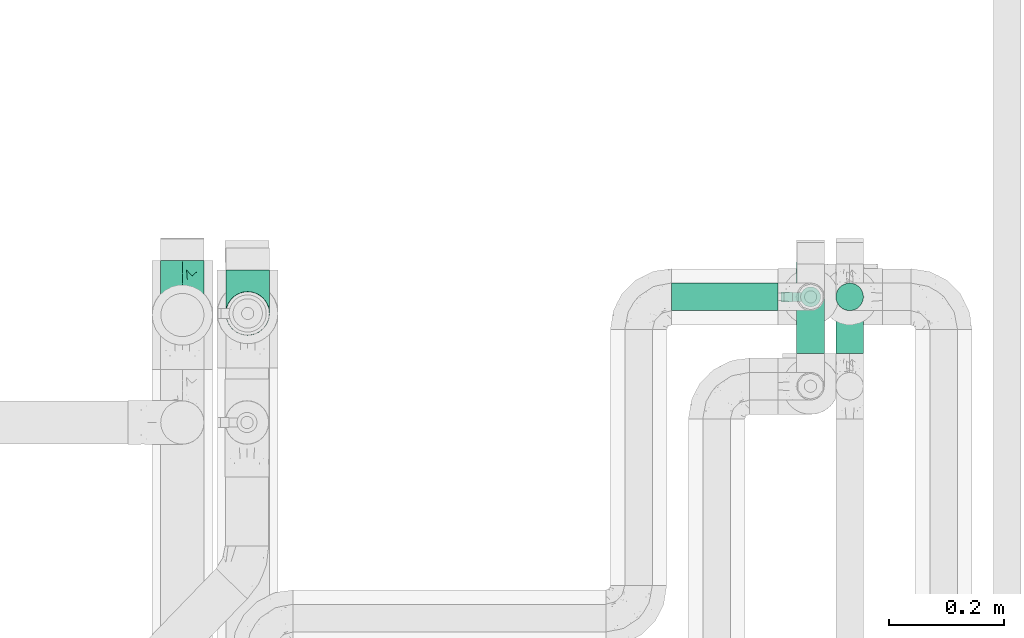
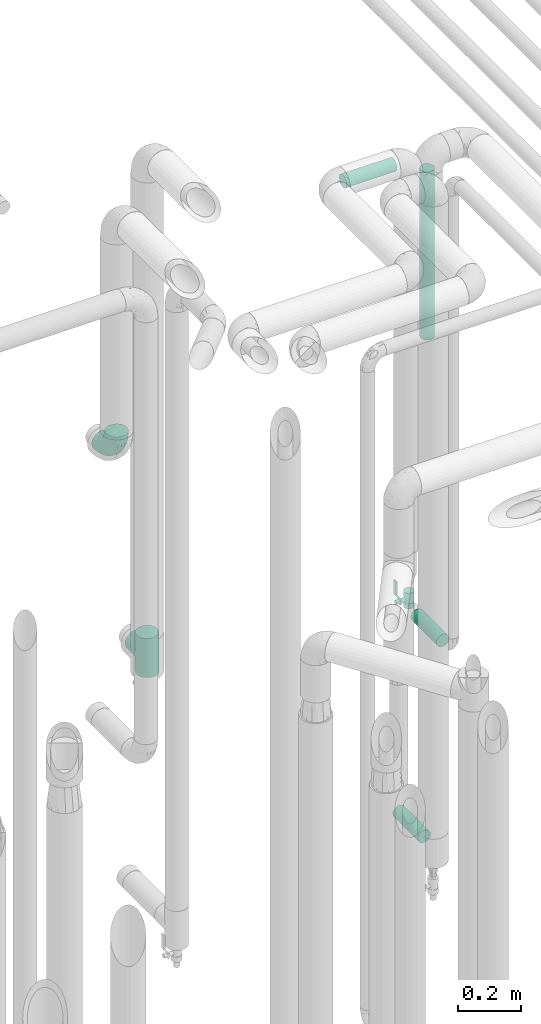
# One storey, part 675 of 827: 4 flow segments, 2 flow fittings, 1 flow controller.
"""IFC2X3 building model written with IfcOpenShell, lengths in millimetres."""

from ifc_helpers import new_model, entity, si_unit, converted_unit, derived_unit, direction, frame, origin, origin_2d_with_axis, place, context, subcontext, project, spatial, polyline, circle, outline, extrude, faceted_brep, source, transform, mapped, material, material_list, type_object, type_shapes, element, save


model = new_model("IFC2X3")

# Units and contexts
model_context = context("Model", 3, precision=0.01, world=origin(), true_north=direction((6.12303176911189e-17, 1.0)))
body_context = subcontext(model_context, "Body", "Model", "MODEL_VIEW")
ifc_project = project(units=[si_unit("LENGTHUNIT", "METRE", prefix="MILLI"), si_unit("AREAUNIT", "SQUARE_METRE"), si_unit("VOLUMEUNIT", "CUBIC_METRE"), converted_unit("PLANEANGLEUNIT", "DEGREE", entity("IfcRatioMeasure", 0.0174532925199433), si_unit("PLANEANGLEUNIT", "RADIAN"), dimensions=[0, 0, 0, 0, 0, 0, 0]), si_unit("MASSUNIT", "GRAM", prefix="KILO"), derived_unit("MASSDENSITYUNIT", [(si_unit("MASSUNIT", "GRAM", prefix="KILO"), 1), (si_unit("LENGTHUNIT", "METRE"), -3)]), derived_unit("MOMENTOFINERTIAUNIT", [(si_unit("LENGTHUNIT", "METRE"), 4)]), si_unit("TIMEUNIT", "SECOND"), si_unit("FREQUENCYUNIT", "HERTZ"), si_unit("THERMODYNAMICTEMPERATUREUNIT", "DEGREE_CELSIUS"), derived_unit("THERMALTRANSMITTANCEUNIT", [(si_unit("MASSUNIT", "GRAM", prefix="KILO"), 1), (si_unit("THERMODYNAMICTEMPERATUREUNIT", "KELVIN"), -1), (si_unit("TIMEUNIT", "SECOND"), -3)]), derived_unit("VOLUMETRICFLOWRATEUNIT", [(si_unit("LENGTHUNIT", "METRE"), 3), (si_unit("TIMEUNIT", "SECOND"), -1)]), derived_unit("MASSFLOWRATEUNIT", [(si_unit("MASSUNIT", "GRAM", prefix="KILO"), 1), (si_unit("TIMEUNIT", "SECOND"), -1)]), derived_unit("ROTATIONALFREQUENCYUNIT", [(si_unit("TIMEUNIT", "SECOND"), -1)]), si_unit("ELECTRICCURRENTUNIT", "AMPERE"), si_unit("ELECTRICVOLTAGEUNIT", "VOLT"), si_unit("POWERUNIT", "WATT"), si_unit("FORCEUNIT", "NEWTON", prefix="KILO"), si_unit("ILLUMINANCEUNIT", "LUX"), si_unit("LUMINOUSFLUXUNIT", "LUMEN"), si_unit("LUMINOUSINTENSITYUNIT", "CANDELA"), derived_unit("USERDEFINED", [(si_unit("MASSUNIT", "GRAM", prefix="KILO"), -1), (si_unit("LENGTHUNIT", "METRE"), -2), (si_unit("TIMEUNIT", "SECOND"), 3), (si_unit("LUMINOUSFLUXUNIT", "LUMEN"), 1)]), derived_unit("LINEARVELOCITYUNIT", [(si_unit("LENGTHUNIT", "METRE"), 1), (si_unit("TIMEUNIT", "SECOND"), -1)]), si_unit("PRESSUREUNIT", "PASCAL"), derived_unit("USERDEFINED", [(si_unit("LENGTHUNIT", "METRE"), -2), (si_unit("MASSUNIT", "GRAM", prefix="KILO"), 1), (si_unit("TIMEUNIT", "SECOND"), -2)]), derived_unit("LINEARFORCEUNIT", [(si_unit("MASSUNIT", "GRAM", prefix="KILO"), 1), (si_unit("LENGTHUNIT", "METRE"), 1), (si_unit("TIMEUNIT", "SECOND"), -2), (si_unit("LENGTHUNIT", "METRE"), -1)]), derived_unit("PLANARFORCEUNIT", [(si_unit("MASSUNIT", "GRAM", prefix="KILO"), 1), (si_unit("LENGTHUNIT", "METRE"), 1), (si_unit("TIMEUNIT", "SECOND"), -2), (si_unit("LENGTHUNIT", "METRE"), -2)])], contexts=[model_context])

# Site, building, storey
site_placement = place(None, origin())
site = spatial("IfcSite", under=ifc_project, at=site_placement, CompositionType="ELEMENT")
building_placement = place(site_placement, origin())
building = spatial("IfcBuilding", under=site, at=building_placement, CompositionType="ELEMENT")
storey_placement = place(building_placement, frame((0.0, 0.0, 28200.0)))
storey = spatial("IfcBuildingStorey", under=building, at=storey_placement, Name="08", CompositionType="ELEMENT", Elevation=28200.0)

# Flow segments
pipe_segment_type = type_object("IfcPipeSegmentType", PredefinedType="NOTDEFINED")
flow_segment_1_placement = place(storey_placement, frame((47694.42, 15281.43, 2287.62)))
element("IfcFlowSegment", 1, at=flow_segment_1_placement, inside=storey, type_object=pipe_segment_type, context=body_context, shape_type="SweptSolid", body=[
    extrude(circle(Radius=24.0, at=origin_2d_with_axis()), frame((25.6, 25.6, 0.0)), (0.0, 0.0, 1.0), 655.375000000061),
])
flow_segment_2_placement = place(storey_placement, frame((47694.42, 15208.24, 1134.4)))
element("IfcFlowSegment", 2, at=flow_segment_2_placement, inside=storey, type_object=pipe_segment_type, context=body_context, shape_type="SweptSolid", body=[
    extrude(circle(Radius=24.0, at=origin_2d_with_axis()), frame((25.6, 0.0, 25.6), z_axis=(0.0, 1.0, 0.0), x_axis=(1.0, 0.0, 0.0)), (0.0, 0.0, 1.0), 162.948395192827),
])
flow_segment_3_placement = place(storey_placement, frame((47409.0, 15281.43, 2974.4)))
element("IfcFlowSegment", 3, at=flow_segment_3_placement, inside=storey, type_object=pipe_segment_type, context=body_context, shape_type="SweptSolid", body=[
    extrude(circle(Radius=24.0, at=origin_2d_with_axis()), frame((0.0, 25.6, 25.6), z_axis=(1.0, 0.0, 0.0), x_axis=(0.0, -1.0, 0.0)), (0.0, 0.0, 1.0), 186.00000000001),
])
flow_segment_4_placement = place(storey_placement, frame((47626.15, 15208.24, 394.65)))
element("IfcFlowSegment", 4, at=flow_segment_4_placement, inside=storey, type_object=pipe_segment_type, context=body_context, shape_type="SweptSolid", body=[
    extrude(circle(Radius=24.0, at=origin_2d_with_axis()), frame((25.6, 0.0, 25.6), z_axis=(0.0, 1.0, 0.0), x_axis=(1.0, 0.0, 0.0)), (0.0, 0.0, 1.0), 160.0),
])

# Flow controller
ifc_material = material()
ifc_material_list = material_list([ifc_material, ifc_material, ifc_material, ifc_material, ifc_material])
valve_type = type_object("IfcValveType", PredefinedType="NOTDEFINED", material=ifc_material_list)
shared_shape_1 = source(origin(), body_context, "Body", "SweptSolid", [
    extrude(circle(Radius=17.5, at=origin_2d_with_axis()), frame((-30.5, 0.0, 0.0), z_axis=(1.0, 0.0, 0.0), x_axis=(0.0, 1.0, 0.0)), (0.0, 0.0, 1.0), 20.3333333333333),
    extrude(circle(Radius=16.0, at=origin_2d_with_axis()), frame((-10.17, 0.0, 0.0), z_axis=(1.0, 0.0, 0.0), x_axis=(0.0, 1.0, 0.0)), (0.0, 0.0, 1.0), 20.3333333333333),
    extrude(circle(Radius=17.5, at=origin_2d_with_axis()), frame((10.17, 0.0, 0.0), z_axis=(1.0, 0.0, 0.0), x_axis=(0.0, 1.0, 0.0)), (0.0, 0.0, 1.0), 20.3333333333333),
    extrude(outline(polyline([(-38.75, -5.0), (-38.75, -10.0), (-17.92, -10.0), (2.08, 5.0), (56.25, 5.0), (56.25, 10.0), (0.42, 10.0), (-19.58, -5.0), (-38.75, -5.0)])), frame((28.75, -8.75, 41.5), z_axis=(0.0, -1.0, 0.0), x_axis=(1.0, 0.0, 0.0)), (0.0, 0.0, -1.0), 17.5),
    extrude(circle(Radius=8.0, at=origin_2d_with_axis()), origin(), (0.0, 0.0, 1.0), 49.0),
])
type_shapes(valve_type, [shared_shape_1])
flow_controller_placement = place(storey_placement, frame((47652.0, 15307.03, 1289.0), z_axis=(-1.0, 0.0, 0.0), x_axis=(0.0, 0.0, 1.0)))
element("IfcFlowController", 5, at=flow_controller_placement, inside=storey, type_object=valve_type, material=ifc_material, context=body_context, shape_type="MappedRepresentation", body=[
    mapped(shared_shape_1, transform((0.0, 0.0, 0.0), scale=1.0)),
])

# Flow fittings
pipe_fitting_type_1 = type_object("IfcPipeFittingType", Name="ADSK_1", PredefinedType="NOTDEFINED", material=ifc_material)
shared_shape_2 = source(origin(), body_context, "Body", "Brep", [
    faceted_brep([(-95.0, 19.02, -32.95), (-95.0, 9.85, -36.75), (-95.0, 0.0, -38.05), (-95.0, -9.85, -36.75), (-95.0, -19.03, -32.95), (-95.0, -26.91, -26.91), (-95.0, -32.95, -19.03), (-95.0, -36.75, -9.85), (-95.0, -38.05, 0.0), (-95.0, -36.75, 9.85), (-95.0, -32.95, 19.02), (-95.0, -26.91, 26.91), (-95.0, -19.03, 32.95), (-95.0, -9.85, 36.75), (-95.0, 0.0, 38.05), (-95.0, 9.85, 36.75), (-95.0, 19.02, 32.95), (-95.0, 26.91, 26.91), (-95.0, 32.95, 19.02), (-95.0, 36.75, 9.85), (-95.0, 38.05, 0.0), (-95.0, 36.75, -9.85), (-95.0, 32.95, -19.03), (-95.0, 26.91, -26.91), (0.0, 95.0, -38.05), (-9.85, 95.0, -36.75), (-19.02, 95.0, -32.95), (-26.91, 95.0, -26.91), (-32.95, 95.0, -19.03), (-36.75, 95.0, -9.85), (-38.05, 95.0, 0.0), (-36.75, 95.0, 9.85), (-32.95, 95.0, 19.02), (-26.91, 95.0, 26.91), (-19.02, 95.0, 32.95), (-9.85, 95.0, 36.75), (0.0, 95.0, 38.05), (9.85, 95.0, 36.75), (19.03, 95.0, 32.95), (26.91, 95.0, 26.91), (32.95, 95.0, 19.02), (36.75, 95.0, 9.85), (38.05, 95.0, 0.0), (36.75, 95.0, -9.85), (32.95, 95.0, -19.03), (26.91, 95.0, -26.91), (19.03, 95.0, -32.95), (9.85, 95.0, -36.75), (-7.99, -4.96, 6.3), (-0.92, 0.92, 0.0), (4.62, 8.1, 8.01), (-76.19, -35.57, 0.0), (-64.32, -32.32, 12.43), (20.51, 62.45, 28.68), (-60.56, -33.52, 0.0), (-70.4, -13.47, 34.42), (-39.61, -5.88, 32.32), (-49.6, 2.07, 37.1), (-70.34, -28.81, 21.71), (14.64, 40.81, 26.5), (5.88, 39.61, 32.32), (3.59, 20.77, 25.31), (-40.45, 68.06, 16.75), (-62.45, -20.51, 28.68), (-44.52, -26.87, 0.0), (-28.47, -20.22, 0.0), (-26.43, -17.83, 8.75), (-76.1, 39.63, 10.76), (-72.74, 37.58, 18.19), (-60.35, 46.18, 14.61), (-13.4, 13.4, 32.12), (-20.77, -3.59, 25.31), (-14.66, 81.47, 35.56), (-6.22, 71.26, 37.92), (-57.5, 42.48, 22.79), (-15.0, 34.74, 37.7), (-27.1, 12.08, 36.05), (-9.2, 28.81, 35.63), (-79.98, 23.7, 30.95), (-73.68, -4.3, 37.48), (-30.74, 21.67, 37.97), (-62.36, 47.59, 6.79), (-72.71, 32.83, 24.69), (-67.42, 7.02, 37.95), (-32.13, 75.27, 24.51), (-43.46, 51.47, 26.26), (-24.98, 73.15, 31.29), (20.59, 41.28, 19.85), (7.79, 16.09, 15.86), (-73.21, 42.39, 0.0), (-54.73, 54.73, 0.0), (-73.44, 15.79, 35.79), (-5.94, 4.32, 20.43), (28.81, 70.34, 21.71), (32.32, 64.32, 12.43), (-53.59, 26.2, 35.09), (-52.02, 19.31, 37.21), (21.38, 33.53, 10.34), (26.87, 44.52, 0.0), (-48.28, 12.14, 38.05), (4.3, 73.68, 37.48), (-44.08, -25.52, 12.79), (-41.28, -20.59, 19.85), (35.57, 76.19, 0.0), (-47.26, 54.3, 20.18), (-47.4, 61.99, 8.58), (-42.39, 73.21, 0.0), (-39.67, 78.86, 7.21), (-45.69, 36.84, 33.11), (-32.83, 50.13, 33.35), (13.47, 70.4, 34.42), (-18.25, 63.73, 36.07), (-40.63, -13.75, 27.22), (-16.63, 46.37, 37.95), (-53.47, 38.79, 28.59), (-26.07, 48.54, 36.15), (-34.51, 34.51, 36.86), (-2.07, 49.6, 37.1), (-22.79, -10.49, 19.23), (-61.73, 28.67, 31.87), (9.65, 14.7, 0.0), (20.22, 28.47, 0.0), (33.52, 60.56, 0.0), (-11.42, -5.44, 13.25), (-14.7, -9.65, 0.0), (-81.47, 14.66, -35.56), (-62.45, -20.51, -28.68), (-71.26, 6.22, -37.92), (-75.27, 32.13, -24.51), (-73.15, 24.98, -31.29), (13.47, 70.4, -34.42), (5.88, 39.61, -32.32), (-2.07, 49.6, -37.1), (-78.86, 39.67, -7.21), (-70.4, -13.47, -34.42), (-39.61, -5.88, -32.32), (-61.99, 47.4, -8.58), (32.32, 64.32, -12.43), (28.81, 70.34, -21.71), (-63.73, 18.25, -36.07), (-50.13, 32.83, -33.35), (4.3, 73.68, -37.48), (-7.02, 67.42, -37.95), (-39.63, 76.1, -10.76), (-46.18, 60.35, -14.61), (-47.59, 62.36, -6.79), (-64.32, -32.32, -12.43), (-26.2, 53.59, -35.09), (-15.79, 73.44, -35.79), (-19.31, 52.02, -37.21), (-37.58, 72.74, -18.19), (-70.34, -28.81, -21.71), (-42.48, 57.5, -22.79), (-38.79, 53.47, -28.59), (-51.47, 43.46, -26.26), (-32.83, 72.71, -24.69), (-46.37, 16.63, -37.95), (-73.68, -4.3, -37.48), (-41.28, -20.59, -19.85), (-44.08, -25.52, -12.79), (13.75, 40.63, -27.22), (20.51, 62.45, -28.68), (-68.06, 40.45, -16.75), (-54.3, 47.26, -20.18), (-12.14, 48.28, -38.05), (-21.67, 30.74, -37.97), (-36.84, 45.69, -33.11), (-11.42, -5.44, -13.25), (7.79, 16.09, -15.86), (4.62, 8.1, -8.01), (-23.7, 79.98, -30.95), (-26.43, -17.83, -8.75), (-7.99, -4.96, -6.3), (-40.81, -14.64, -26.5), (-20.77, -3.59, -25.31), (-34.74, 15.0, -37.7), (-12.08, 27.1, -36.05), (-28.81, 9.2, -35.63), (-22.79, -10.49, -19.23), (21.38, 33.53, -10.34), (20.59, 41.28, -19.85), (-48.54, 26.07, -36.15), (-49.6, 2.07, -37.1), (-13.4, 13.4, -32.12), (3.59, 20.77, -25.31), (-28.67, 61.73, -31.87), (-34.51, 34.51, -36.86), (-5.94, 4.32, -20.43)], [[[0, 1, 2, 3, 4, 5, 6, 7, 8, 9, 10, 11, 12, 13, 14, 15, 16, 17, 18, 19, 20, 21, 22, 23]], [[24, 25, 26, 27, 28, 29, 30, 31, 32, 33, 34, 35, 36, 37, 38, 39, 40, 41, 42, 43, 44, 45, 46, 47]], [[48, 49, 50]], [[51, 52, 9]], [[53, 39, 38]], [[9, 52, 10]], [[54, 52, 51]], [[55, 56, 57]], [[11, 10, 58]], [[59, 60, 61]], [[32, 31, 62]], [[63, 12, 11]], [[63, 55, 12]], [[64, 65, 66]], [[67, 68, 69]], [[70, 56, 71]], [[35, 72, 73]], [[69, 68, 74]], [[75, 76, 77]], [[16, 78, 17]], [[13, 79, 14]], [[76, 75, 80]], [[67, 69, 81]], [[18, 17, 82]], [[14, 79, 83]], [[20, 19, 67]], [[84, 85, 86]], [[87, 61, 88]], [[89, 81, 90]], [[18, 82, 68]], [[15, 91, 16]], [[14, 83, 15]], [[71, 92, 61]], [[17, 78, 82]], [[93, 87, 94]], [[95, 91, 96]], [[97, 98, 94]], [[86, 72, 34]], [[96, 99, 80]], [[37, 36, 100]], [[40, 39, 93]], [[40, 94, 41]], [[64, 66, 101]], [[93, 94, 40]], [[58, 102, 63]], [[94, 103, 41]], [[94, 87, 97]], [[104, 69, 74]], [[34, 33, 86]], [[105, 69, 104]], [[52, 58, 10]], [[106, 107, 30]], [[108, 109, 85]], [[105, 106, 90]], [[53, 110, 60]], [[86, 111, 72]], [[86, 109, 111]], [[33, 84, 86]], [[12, 55, 13]], [[112, 56, 63]], [[110, 38, 37]], [[34, 72, 35]], [[36, 35, 73]], [[111, 113, 73]], [[105, 107, 106]], [[110, 53, 38]], [[74, 114, 85]], [[91, 15, 83]], [[105, 90, 81]], [[107, 62, 31]], [[33, 32, 84]], [[115, 109, 116]], [[111, 115, 113]], [[100, 73, 117]], [[56, 55, 63]], [[79, 55, 57]], [[102, 118, 112]], [[56, 70, 76]], [[100, 110, 37]], [[117, 77, 60]], [[117, 60, 110]], [[60, 70, 61]], [[58, 52, 101]], [[63, 11, 58]], [[39, 53, 93]], [[87, 93, 53]], [[96, 91, 83]], [[78, 91, 119]], [[32, 62, 84]], [[84, 62, 104]], [[86, 85, 109]], [[85, 114, 108]], [[80, 113, 116]], [[117, 73, 113]], [[80, 116, 96]], [[80, 57, 76]], [[71, 112, 118]], [[61, 87, 59]], [[62, 107, 105]], [[97, 120, 121]], [[70, 71, 61]], [[71, 118, 92]], [[73, 100, 36]], [[110, 100, 117]], [[55, 79, 13]], [[83, 79, 57]], [[96, 83, 99]], [[116, 108, 95]], [[50, 97, 88]], [[97, 87, 88]], [[50, 49, 120]], [[122, 94, 98]], [[89, 20, 67]], [[105, 81, 69]], [[89, 67, 81]], [[68, 19, 18]], [[68, 67, 19]], [[74, 68, 82]], [[114, 82, 119]], [[74, 85, 104]], [[82, 114, 74]], [[114, 119, 108]], [[95, 108, 119]], [[116, 109, 108]], [[123, 48, 50]], [[97, 50, 120]], [[123, 50, 88]], [[91, 95, 119]], [[116, 95, 96]], [[84, 104, 85]], [[104, 62, 105]], [[83, 57, 99]], [[57, 80, 99]], [[66, 48, 123]], [[66, 124, 48]], [[118, 66, 123]], [[124, 66, 65]], [[66, 118, 101]], [[54, 64, 52]], [[124, 49, 48]], [[30, 107, 31]], [[91, 78, 16]], [[82, 78, 119]], [[56, 76, 57]], [[77, 76, 70]], [[60, 77, 70]], [[77, 117, 75]], [[117, 113, 75]], [[113, 80, 75]], [[9, 8, 51]], [[103, 94, 122]], [[103, 42, 41]], [[73, 72, 111]], [[113, 115, 116]], [[111, 109, 115]], [[102, 112, 63]], [[71, 56, 112]], [[118, 102, 101]], [[92, 123, 88]], [[123, 92, 118]], [[61, 92, 88]], [[87, 53, 59]], [[60, 59, 53]], [[97, 121, 98]], [[58, 101, 102]], [[64, 101, 52]], [[125, 1, 0]], [[126, 5, 4]], [[2, 1, 127]], [[1, 125, 127]], [[128, 129, 23]], [[130, 131, 132]], [[89, 133, 20]], [[126, 134, 135]], [[136, 89, 90]], [[137, 138, 44]], [[139, 129, 140]], [[24, 141, 142]], [[143, 144, 145]], [[125, 129, 139]], [[6, 146, 7]], [[147, 148, 149]], [[146, 51, 7]], [[143, 150, 144]], [[146, 6, 151]], [[152, 153, 154]], [[126, 4, 134]], [[0, 23, 129]], [[28, 155, 150]], [[43, 42, 103]], [[54, 146, 64]], [[139, 156, 127]], [[157, 3, 2]], [[151, 158, 159]], [[160, 131, 161]], [[22, 21, 162]], [[136, 144, 163]], [[149, 164, 165]], [[24, 142, 25]], [[166, 140, 154]], [[154, 129, 128]], [[143, 30, 29]], [[167, 168, 169]], [[155, 28, 27]], [[26, 170, 27]], [[171, 167, 172]], [[26, 25, 148]], [[27, 170, 155]], [[173, 135, 174]], [[144, 150, 152]], [[175, 176, 177]], [[24, 47, 141]], [[45, 161, 46]], [[148, 25, 142]], [[176, 175, 165]], [[64, 159, 171]], [[138, 45, 44]], [[130, 46, 161]], [[137, 44, 43]], [[178, 159, 158]], [[137, 103, 122]], [[163, 144, 152]], [[136, 133, 89]], [[103, 137, 43]], [[6, 5, 151]], [[178, 158, 173]], [[134, 4, 3]], [[178, 173, 174]], [[137, 98, 179]], [[145, 90, 106]], [[138, 180, 161]], [[46, 130, 47]], [[136, 90, 145]], [[133, 162, 21]], [[23, 22, 128]], [[139, 140, 181]], [[139, 181, 156]], [[157, 127, 182]], [[157, 134, 3]], [[182, 177, 135]], [[182, 135, 134]], [[135, 183, 174]], [[131, 130, 161]], [[141, 130, 132]], [[160, 180, 184]], [[131, 183, 176]], [[5, 126, 151]], [[158, 151, 126]], [[180, 138, 137]], [[161, 45, 138]], [[149, 148, 142]], [[170, 148, 185]], [[22, 162, 128]], [[128, 162, 163]], [[129, 154, 140]], [[154, 153, 166]], [[165, 156, 186]], [[182, 127, 156]], [[165, 186, 149]], [[165, 132, 176]], [[131, 184, 183]], [[187, 167, 178]], [[184, 168, 187]], [[167, 169, 172]], [[184, 180, 168]], [[174, 183, 184]], [[127, 157, 2]], [[134, 157, 182]], [[130, 141, 47]], [[142, 141, 132]], [[149, 142, 164]], [[186, 166, 147]], [[180, 179, 168]], [[169, 179, 120]], [[137, 179, 180]], [[179, 121, 120]], [[106, 30, 143]], [[136, 145, 144]], [[106, 143, 145]], [[150, 29, 28]], [[150, 143, 29]], [[152, 150, 155]], [[153, 155, 185]], [[152, 154, 163]], [[155, 153, 152]], [[153, 185, 166]], [[147, 166, 185]], [[186, 140, 166]], [[169, 120, 49]], [[169, 49, 172]], [[179, 169, 168]], [[148, 147, 185]], [[186, 147, 149]], [[128, 163, 154]], [[163, 162, 136]], [[142, 132, 164]], [[132, 165, 164]], [[171, 124, 65]], [[124, 171, 172]], [[64, 146, 159]], [[171, 159, 178]], [[171, 65, 64]], [[172, 49, 124]], [[162, 133, 136]], [[20, 133, 21]], [[148, 170, 26]], [[155, 170, 185]], [[131, 176, 132]], [[177, 176, 183]], [[135, 177, 183]], [[177, 182, 175]], [[182, 156, 175]], [[156, 165, 175]], [[51, 146, 54]], [[51, 8, 7]], [[129, 125, 0]], [[127, 125, 139]], [[140, 186, 181]], [[156, 181, 186]], [[158, 126, 173]], [[135, 173, 126]], [[187, 178, 174]], [[171, 178, 167]], [[184, 187, 174]], [[167, 187, 168]], [[180, 160, 161]], [[184, 131, 160]], [[98, 137, 122]], [[98, 121, 179]], [[151, 159, 146]]]),
])
type_shapes(pipe_fitting_type_1, [shared_shape_2])
flow_fitting_1_placement = place(storey_placement, frame((46556.77, 15275.36, 2250.05), z_axis=(1.0, 0.0, 0.0), x_axis=(0.0, 0.0, -1.0)))
element("IfcFlowFitting", 6, at=flow_fitting_1_placement, inside=storey, type_object=pipe_fitting_type_1, material=ifc_material, Name="ADSK_1", ObjectType="ADSK_1", context=body_context, shape_type="MappedRepresentation", body=[
    mapped(shared_shape_2, transform((0.0, 0.0, 0.0), scale=1.0)),
])
pipe_fitting_type_2 = type_object("IfcPipeFittingType", Name="ADSK_1", PredefinedType="NOTDEFINED", material=ifc_material)
shared_shape_3 = source(origin(), body_context, "Body", "Brep", [
    faceted_brep([(-76.0, 9.85, -36.75), (-76.0, 0.0, -38.05), (-76.0, -9.85, -36.75), (-76.0, -19.03, -32.95), (-76.0, -22.97, -29.93), (-76.0, -26.91, -26.91), (-76.0, -29.93, -22.97), (-76.0, -32.95, -19.03), (-76.0, -34.85, -14.44), (-76.0, -36.75, -9.85), (-76.0, -38.05, 0.0), (-76.0, -36.75, 9.85), (-76.0, -34.85, 14.44), (-76.0, -32.95, 19.02), (-76.0, -29.93, 22.97), (-76.0, -26.91, 26.91), (-76.0, -22.97, 29.93), (-76.0, -19.03, 32.95), (-76.0, -9.85, 36.75), (-76.0, 0.0, 38.05), (-76.0, 9.85, 36.75), (-76.0, 19.02, 32.95), (-76.0, 26.91, 26.91), (-76.0, 32.95, 19.02), (-76.0, 36.75, 9.85), (-76.0, 38.05, 0.0), (-76.0, 36.75, -9.85), (-76.0, 32.95, -19.03), (-76.0, 26.91, -26.91), (-76.0, 19.02, -32.95), (76.0, 26.91, -26.91), (76.0, 32.95, -19.03), (76.0, 36.75, -9.85), (76.0, 38.05, 0.0), (76.0, 36.75, 9.85), (76.0, 32.95, 19.02), (76.0, 26.91, 26.91), (76.0, 19.02, 32.95), (76.0, 9.85, 36.75), (76.0, 0.0, 38.05), (76.0, -9.85, 36.75), (76.0, -19.03, 32.95), (76.0, -22.97, 29.93), (76.0, -26.91, 26.91), (76.0, -29.93, 22.97), (76.0, -32.95, 19.02), (76.0, -34.85, 14.44), (76.0, -36.75, 9.85), (76.0, -38.05, 0.0), (76.0, -36.75, -9.85), (76.0, -34.85, -14.44), (76.0, -32.95, -19.03), (76.0, -29.93, -22.97), (76.0, -26.91, -26.91), (76.0, -22.97, -29.93), (76.0, -19.03, -32.95), (76.0, -9.85, -36.75), (76.0, 0.0, -38.05), (76.0, 9.85, -36.75), (76.0, 19.02, -32.95), (36.99, -36.99, 8.94), (38.05, -38.05, 0.0), (-36.99, -36.99, 8.94), (-38.05, -38.05, 0.0), (35.51, -35.51, 12.97), (34.04, -34.04, 17.0), (18.81, -18.81, 33.08), (29.74, -29.74, 23.73), (24.56, -24.56, 29.06), (-35.51, -35.51, 12.97), (-34.04, -34.04, 17.0), (-18.81, -18.81, 33.08), (-29.74, -29.74, 23.73), (-24.56, -24.56, 29.06), (-12.7, -12.7, 35.87), (6.4, -6.4, 37.51), (12.7, -12.7, 35.87), (0.0, 0.0, 38.05), (-6.4, -6.4, 37.51), (6.4, -6.4, -37.51), (0.0, 0.0, -38.05), (12.7, -12.7, -35.87), (-24.56, -24.56, -29.06), (-6.4, -6.4, -37.51), (-35.51, -35.51, -12.97), (-36.99, -36.99, -8.94), (-29.74, -29.74, -23.73), (-12.7, -12.7, -35.87), (18.81, -18.81, -33.08), (24.56, -24.56, -29.06), (-34.04, -34.04, -17.0), (29.74, -29.74, -23.73), (36.99, -36.99, -8.94), (35.51, -35.51, -12.97), (34.04, -34.04, -17.0), (-18.81, -18.81, -33.08), (9.85, -76.0, -36.75), (19.03, -76.0, -32.95), (26.91, -76.0, -26.91), (32.95, -76.0, -19.03), (36.75, -76.0, -9.85), (38.05, -76.0, 0.0), (36.75, -76.0, 9.85), (32.95, -76.0, 19.02), (26.91, -76.0, 26.91), (19.03, -76.0, 32.95), (9.85, -76.0, 36.75), (0.0, -76.0, 38.05), (-9.85, -76.0, 36.75), (-19.02, -76.0, 32.95), (-26.91, -76.0, 26.91), (-32.95, -76.0, 19.02), (-36.75, -76.0, 9.85), (-38.05, -76.0, 0.0), (-36.75, -76.0, -9.85), (-32.95, -76.0, -19.03), (-26.91, -76.0, -26.91), (-19.02, -76.0, -32.95), (-9.85, -76.0, -36.75), (0.0, -76.0, -38.05)], [[[0, 1, 2, 3, 4, 5, 6, 7, 8, 9, 10, 11, 12, 13, 14, 15, 16, 17, 18, 19, 20, 21, 22, 23, 24, 25, 26, 27, 28, 29]], [[30, 31, 32, 33, 34, 35, 36, 37, 38, 39, 40, 41, 42, 43, 44, 45, 46, 47, 48, 49, 50, 51, 52, 53, 54, 55, 56, 57, 58, 59]], [[48, 47, 60]], [[60, 61, 48]], [[62, 10, 63]], [[47, 46, 64]], [[46, 45, 65]], [[41, 66, 42]], [[43, 67, 45, 44]], [[67, 43, 68]], [[45, 67, 65]], [[68, 43, 42]], [[11, 69, 12]], [[70, 12, 69]], [[10, 62, 11]], [[11, 62, 69]], [[71, 17, 16]], [[72, 73, 15]], [[72, 15, 14, 13]], [[15, 73, 16]], [[71, 74, 17]], [[72, 13, 70]], [[46, 65, 64]], [[42, 66, 68]], [[40, 39, 75]], [[47, 64, 60]], [[66, 41, 76]], [[75, 76, 40]], [[75, 39, 77]], [[78, 77, 19]], [[76, 41, 40]], [[23, 22, 36, 35]], [[24, 23, 35, 34]], [[21, 20, 38, 37]], [[22, 21, 37, 36]], [[38, 20, 19, 77, 39]], [[25, 24, 34, 33]], [[70, 13, 12]], [[78, 18, 74]], [[18, 78, 19]], [[18, 17, 74]], [[71, 16, 73]], [[28, 27, 31, 30]], [[26, 32, 31, 27]], [[25, 33, 32, 26]], [[29, 28, 30, 59]], [[57, 56, 79]], [[58, 57, 80, 1, 0]], [[79, 56, 81]], [[82, 5, 4]], [[59, 58, 0, 29]], [[56, 55, 81]], [[57, 79, 80]], [[80, 83, 1]], [[9, 84, 85]], [[86, 7, 6, 5]], [[83, 87, 2]], [[1, 83, 2]], [[87, 3, 2]], [[88, 54, 89]], [[54, 53, 89]], [[8, 90, 84]], [[88, 55, 54]], [[91, 89, 53]], [[52, 51, 91, 53]], [[55, 88, 81]], [[49, 92, 93]], [[92, 49, 48]], [[94, 50, 93]], [[61, 92, 48]], [[85, 63, 10]], [[51, 94, 91]], [[82, 4, 95]], [[49, 93, 50]], [[4, 3, 95]], [[5, 82, 86]], [[94, 51, 50]], [[95, 3, 87]], [[9, 8, 84]], [[90, 8, 7]], [[9, 85, 10]], [[90, 7, 86]], [[96, 97, 98, 99, 100, 101, 102, 103, 104, 105, 106, 107, 108, 109, 110, 111, 112, 113, 114, 115, 116, 117, 118, 119]], [[62, 63, 113]], [[112, 62, 113]], [[110, 109, 73]], [[72, 111, 110]], [[70, 112, 111]], [[74, 109, 108]], [[112, 70, 69, 62]], [[73, 72, 110]], [[70, 111, 72]], [[74, 71, 109]], [[107, 77, 78]], [[74, 108, 78]], [[73, 109, 71]], [[78, 108, 107]], [[75, 107, 106]], [[105, 76, 106]], [[103, 102, 65]], [[67, 104, 103]], [[68, 105, 104]], [[60, 102, 101]], [[68, 66, 105]], [[76, 75, 106]], [[66, 76, 105]], [[61, 60, 101]], [[65, 67, 103]], [[102, 60, 64, 65]], [[68, 104, 67]], [[107, 75, 77]], [[61, 101, 92]], [[100, 92, 101]], [[98, 97, 89]], [[94, 100, 99]], [[98, 91, 99]], [[81, 97, 96]], [[100, 94, 93, 92]], [[89, 91, 98]], [[94, 99, 91]], [[81, 88, 97]], [[119, 80, 79]], [[81, 96, 79]], [[89, 97, 88]], [[79, 96, 119]], [[83, 119, 118]], [[117, 87, 118]], [[115, 114, 90]], [[86, 116, 115]], [[82, 117, 116]], [[85, 114, 113]], [[82, 95, 117]], [[87, 83, 118]], [[95, 87, 117]], [[63, 85, 113]], [[90, 86, 115]], [[114, 85, 84, 90]], [[82, 116, 86]], [[119, 83, 80]]]),
])
type_shapes(pipe_fitting_type_2, [shared_shape_3])
flow_fitting_2_placement = place(storey_placement, frame((46670.56, 15278.08, 1442.25), z_axis=(-1.0, 0.0, 0.0), x_axis=(0.0, 0.0, -1.0)))
element("IfcFlowFitting", 7, at=flow_fitting_2_placement, inside=storey, type_object=pipe_fitting_type_2, material=ifc_material, Name="ADSK_1", ObjectType="ADSK_1", context=body_context, shape_type="MappedRepresentation", body=[
    mapped(shared_shape_3, transform((0.0, 0.0, 0.0), scale=1.0)),
])

save(model, "model.ifc")
